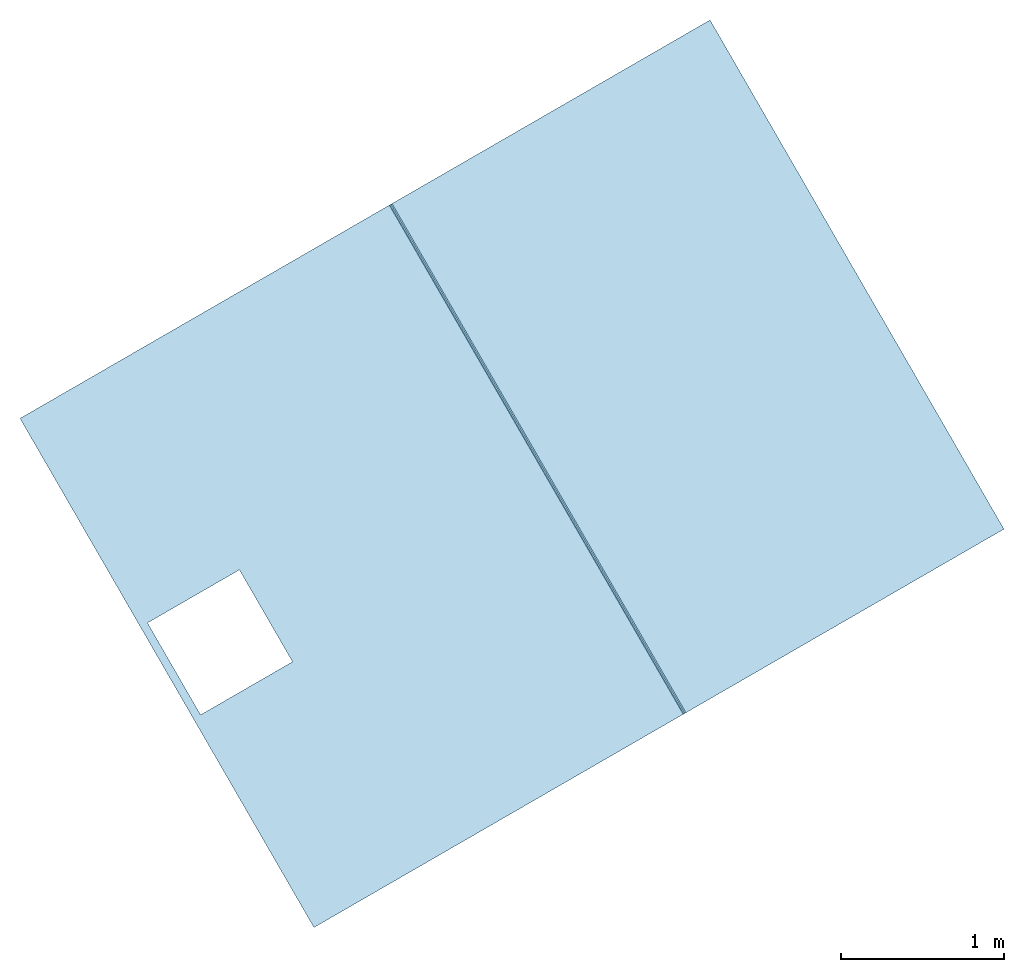
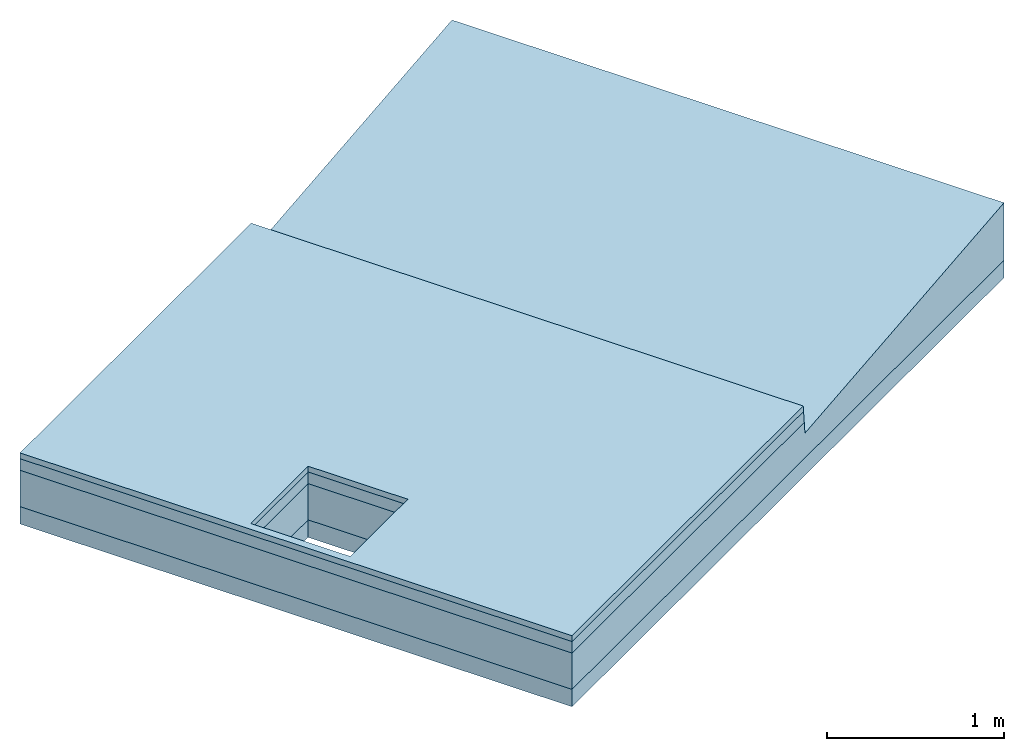
# One storey: 4 slabs.
"""IFC4 building model written with IfcOpenShell, lengths in millimetres."""

from ifc_helpers import new_model, si_unit, frame, origin_with_axes, place, context, subcontext, project, spatial, triangles, material, type_object, element, save


model = new_model("IFC4")

# Units and contexts
model_context = context("Model", 3, world=origin_with_axes())
body_context = subcontext(model_context, "Body", "Model", "MODEL_VIEW")
ifc_project = project(units=[si_unit("LENGTHUNIT", "METRE", prefix="MILLI"), si_unit("AREAUNIT", "SQUARE_METRE"), si_unit("VOLUMEUNIT", "CUBIC_METRE")], contexts=[model_context])

# Sites, buildings, storey
site_1_placement = place(None, origin_with_axes())
site_1 = spatial("IfcSite", under=ifc_project, at=site_1_placement, CompositionType="COMPLEX")
site_2_placement = place(site_1_placement, frame((17320.50807568878, 30000.000000000065, 0.0), z_axis=(0.0, 0.0, 1.0), x_axis=(-0.5000000000000003, 0.8660254037844387, 0.0)))
site_2 = spatial("IfcSite", under=site_1, at=site_2_placement, CompositionType="PARTIAL")
building_1_placement = place(site_2_placement, origin_with_axes())
building_1 = spatial("IfcBuilding", under=site_2, at=building_1_placement, Name="bridge road connection", CompositionType="COMPLEX")
building_2_placement = place(building_1_placement, frame((-8.374172466574236e-11, 4.3314685171935707e-10, 2.6349766812927553e-11), z_axis=(-1.5815362361441082e-15, -2.9936039337702353e-15, 1.0), x_axis=(-1.0, -2.786659791809143e-14, -1.5815362361441902e-15)))
building_2 = spatial("IfcBuilding", under=building_1, at=building_2_placement, Name="bridge - road segment", CompositionType="PARTIAL")
storey_placement = place(building_2_placement, frame((0.0, 0.0, 0.0), z_axis=(0.0, 0.0, 1.0), x_axis=(1.0, 4.73449309792135e-30, -3.944304526105059e-31)))
storey = spatial("IfcBuildingStorey", under=building_2, at=storey_placement, Name="road bridge road", CompositionType="ELEMENT", Elevation=2.6349766812927553e-11)

# Slabs
ifc_material_1 = material(Name="material_stone_generic")
slab_type_1 = type_object("IfcSlabType", Name="road base course - bridge road", PredefinedType="USERDEFINED")
slab_1_placement = place(storey_placement, frame((8.085407898761331e-11, -7560.249999996269, -1.8047785488317828e-13), z_axis=(0.0, 0.0, 1.0), x_axis=(1.0, 4.73449309792135e-30, -3.944304526105059e-31)))
element("IfcSlab", 1, at=slab_1_placement, inside=storey, type_object=slab_type_1, material=ifc_material_1, Name="road base course - bridge road", context=body_context, shape_type="Tessellation", body=[
    triangles([(1800.0000000000155, -2439.7499999956285, -489.99999999999505), (1800.0000000000184, 2439.7499999956285, -369.9999999999922), (1800.000000000027, -2439.74999999564, -369.99999999999216), (1800.0000000001107, 2439.749999995634, -489.99999999974705), (-1799.999999999981, -2439.7499999956285, -369.9999999999922), (-325.0000000009139, -2389.7500000114123, -369.99999999999216), (-1799.999999999978, 2439.74999999564, -369.9999999999922), (1800.000000000027, -2439.74999999564, -369.99999999999216), (-325.0000000009225, -1739.750000011416, -369.99999999999204), (324.99999999908283, -2389.7500000114123, -369.99999999999216), (324.9999999990829, -1739.750000011416, -369.99999999999204), (1800.0000000000184, 2439.7499999956285, -369.9999999999922), (1800.000000000027, -2439.74999999564, -369.99999999999216), (-1799.999999999981, -2439.7499999956285, -489.99999999999505), (1800.0000000000155, -2439.7499999956285, -489.99999999999505), (-1799.999999999981, -2439.7499999956285, -369.9999999999922), (-1799.999999999978, 2439.74999999564, -369.9999999999922), (1800.0000000001107, 2439.749999995634, -489.99999999974705), (-1800.0000000000819, 2439.749999995634, -489.9999999997472), (1800.0000000000184, 2439.7499999956285, -369.9999999999922), (-1799.999999999978, 2439.74999999564, -369.9999999999922), (-1799.999999999981, -2439.7499999956285, -489.99999999999505), (-1799.999999999981, -2439.7499999956285, -369.9999999999922), (-1800.0000000000819, 2439.749999995634, -489.9999999997472), (1800.0000000001107, 2439.749999995634, -489.99999999974705), (-1799.999999999981, -2439.7499999956285, -489.99999999999505), (-1800.0000000000819, 2439.749999995634, -489.9999999997472), (-325.0000000009138, -1739.750000011416, -489.9999999999943), (-325.00000000091677, -2389.7500000114183, -489.9999999999938), (324.99999999908, -1739.750000011416, -489.9999999999938), (324.99999999908283, -2389.7500000114183, -489.99999999999386), (1800.0000000000155, -2439.7499999956285, -489.99999999999505), (-325.00000000091677, -2389.7500000114183, -489.9999999999938), (324.99999999908283, -2389.7500000114123, -369.99999999999216), (324.99999999908283, -2389.7500000114183, -489.99999999999386), (-325.0000000009139, -2389.7500000114123, -369.99999999999216), (324.99999999908283, -2389.7500000114123, -369.99999999999216), (324.99999999908, -1739.750000011416, -489.9999999999938), (324.99999999908283, -2389.7500000114183, -489.99999999999386), (324.9999999990829, -1739.750000011416, -369.99999999999204), (324.99999999908, -1739.750000011416, -489.9999999999938), (-325.0000000009225, -1739.750000011416, -369.99999999999204), (-325.0000000009138, -1739.750000011416, -489.9999999999943), (324.9999999990829, -1739.750000011416, -369.99999999999204), (-325.0000000009138, -1739.750000011416, -489.9999999999943), (-325.0000000009139, -2389.7500000114123, -369.99999999999216), (-325.00000000091677, -2389.7500000114183, -489.9999999999938), (-325.0000000009225, -1739.750000011416, -369.99999999999204)], [[1, 2, 3], [2, 1, 4], [5, 6, 7], [6, 5, 8], [7, 6, 9], [6, 8, 10], [10, 8, 11], [11, 8, 12], [9, 12, 7], [12, 9, 11], [13, 14, 15], [14, 13, 16], [17, 18, 19], [18, 17, 20], [21, 22, 23], [22, 21, 24], [25, 26, 27], [26, 25, 28], [26, 28, 29], [28, 25, 30], [30, 25, 31], [31, 25, 32], [29, 32, 26], [32, 29, 31], [33, 34, 35], [34, 33, 36], [37, 38, 39], [38, 37, 40], [41, 42, 43], [42, 41, 44], [45, 46, 47], [46, 45, 48]]),
])
ifc_material_2 = material(Name="bitumen_generic")
slab_type_2 = type_object("IfcSlabType", Name="bridge road - road asphalt course", PredefinedType="USERDEFINED")
slab_2_placement = place(storey_placement, frame((0.0, 0.0, 0.0), z_axis=(0.0, 0.0, 1.0), x_axis=(1.0, 4.73449309792135e-30, -3.944304526105059e-31)))
element("IfcSlab", 2, at=slab_2_placement, inside=storey, type_object=slab_type_2, material=ifc_material_2, Name="bridge road - road asphalt course", ObjectType="core", context=body_context, shape_type="Tessellation", body=[
    triangles([(-1799.999999999984, -7384.611130885971, -39.999999999995964), (1800.0000000000289, -7376.611130886018, -119.99999999999653), (-1799.9999999999848, -7376.611130886019, -119.99999999999653), (1800.000000000029, -7384.61113088597, -39.999999999995964), (-1799.999999999984, -7384.611130885971, -39.999999999995964), (-1799.9999999999845, -10000.00000000001, -119.99999999999653), (-1799.9999999999848, -10000.00000000001, -39.99999999999524), (-1799.9999999999848, -7376.611130886019, -119.99999999999653), (-1799.9999999999848, -10000.00000000001, -39.99999999999524), (-325.00000000082576, -9950.000000007683, -39.99999999999583), (-1799.999999999984, -7384.611130885971, -39.999999999995964), (1800.0000000000284, -10000.00000000001, -39.99999999999524), (324.99999999917424, -9950.000000007682, -39.99999999999582), (324.9999999991793, -9300.000000007683, -39.99999999999597), (-325.0000000008209, -9300.000000007683, -39.99999999999599), (1800.000000000029, -7384.61113088597, -39.999999999995964), (1800.0000000000284, -10000.00000000001, -39.99999999999524), (-1799.9999999999845, -10000.00000000001, -119.99999999999653), (1800.0000000000289, -10000.00000000001, -119.99999999999653), (-1799.9999999999848, -10000.00000000001, -39.99999999999524), (1800.0000000000289, -7376.611130886018, -119.99999999999653), (-1799.9999999999845, -10000.00000000001, -119.99999999999653), (-1799.9999999999848, -7376.611130886019, -119.99999999999653), (-325.0000000008204, -9300.000000007683, -119.99999999999653), (-325.0000000008251, -9950.000000007683, -119.99999999999653), (324.9999999991751, -9300.000000007683, -119.99999999999653), (324.9999999991751, -9950.000000007682, -119.99999999999656), (1800.0000000000289, -10000.00000000001, -119.99999999999653), (1800.0000000000289, -7376.611130886018, -119.99999999999653), (1800.0000000000284, -10000.00000000001, -39.99999999999524), (1800.0000000000289, -10000.00000000001, -119.99999999999653), (1800.000000000029, -7384.61113088597, -39.999999999995964), (324.9999999991793, -9300.000000007683, -39.99999999999597), (-325.0000000008204, -9300.000000007683, -119.99999999999653), (324.9999999991751, -9300.000000007683, -119.99999999999653), (-325.0000000008209, -9300.000000007683, -39.99999999999599), (-325.0000000008204, -9300.000000007683, -119.99999999999653), (-325.00000000082576, -9950.000000007683, -39.99999999999583), (-325.0000000008251, -9950.000000007683, -119.99999999999653), (-325.0000000008209, -9300.000000007683, -39.99999999999599), (-325.0000000008251, -9950.000000007683, -119.99999999999653), (324.99999999917424, -9950.000000007682, -39.99999999999582), (324.9999999991751, -9950.000000007682, -119.99999999999656), (-325.00000000082576, -9950.000000007683, -39.99999999999583), (324.9999999991793, -9300.000000007683, -39.99999999999597), (324.9999999991751, -9950.000000007682, -119.99999999999656), (324.99999999917424, -9950.000000007682, -39.99999999999582), (324.9999999991751, -9300.000000007683, -119.99999999999653)], [[1, 2, 3], [2, 1, 4], [5, 6, 7], [6, 5, 8], [9, 10, 11], [10, 9, 12], [10, 12, 13], [13, 12, 14], [11, 15, 16], [15, 11, 10], [16, 15, 14], [16, 14, 12], [17, 18, 19], [18, 17, 20], [21, 22, 23], [22, 21, 24], [22, 24, 25], [24, 21, 26], [26, 21, 27], [25, 28, 22], [28, 25, 27], [28, 27, 21], [29, 30, 31], [30, 29, 32], [33, 34, 35], [34, 33, 36], [37, 38, 39], [38, 37, 40], [41, 42, 43], [42, 41, 44], [45, 46, 47], [46, 45, 48]]),
])
ifc_material_3 = material(Name="material_gravel_generic")
slab_type_3 = type_object("IfcSlabType", Name="road bridge road", PredefinedType="USERDEFINED")
slab_3_placement = place(storey_placement, frame((0.0, 0.0, 0.0), z_axis=(0.0, 0.0, 1.0), x_axis=(1.0, 4.73449309792135e-30, -3.944304526105059e-31)))
element("IfcSlab", 3, at=slab_3_placement, inside=storey, type_object=slab_type_3, material=ifc_material_3, Name="road bridge road", context=body_context, shape_type="Tessellation", body=[
    triangles([(1800.0000000000123, -5120.500000000176, -369.9999999999924), (1800.0000000000177, -10000.000000000033, -119.99999999999577), (1800.0000000000118, -10000.000000000033, -369.9999999999924), (1800.0000000000064, -7368.710387081809, -199.0074380419954), (1800.0000000000123, -7376.611130886025, -119.99999999999574), (1800.0000000000123, -5120.500000000211, 25.81360066616533), (1800.000000000018, -5120.5000000001655, -119.9999999999958), (-1799.9999999999811, -5120.500000000159, -119.99999999999577), (1800.0000000000123, -5120.500000000176, -369.9999999999924), (-1799.999999999984, -5120.500000000159, -369.9999999999924), (1800.000000000018, -5120.5000000001655, -119.9999999999958), (1800.0000000000123, -5120.500000000211, 25.81360066616533), (-1799.9999999999898, -5120.500000000206, 25.813600666093855), (-1799.9999999999957, -7376.611130886019, -119.9999999998644), (-1799.9999999999902, -10000.000000000033, -369.9999999999924), (-1799.9999999999902, -10000.000000000033, -119.9999999999958), (-1799.9999999999957, -7368.710387081815, -199.00743804186402), (-1799.999999999984, -5120.500000000159, -369.9999999999924), (-1799.9999999999898, -5120.500000000206, 25.813600666093855), (-1799.9999999999811, -5120.500000000159, -119.99999999999577), (1800.0000000000177, -10000.000000000033, -119.99999999999577), (-325.00000000083054, -9950.000000007685, -119.99999999997891), (-1799.9999999999902, -10000.000000000033, -119.9999999999958), (324.99999999917486, -9950.00000000768, -119.9999999999908), (324.9999999991749, -9300.00000000769, -119.9999999999771), (1800.0000000000123, -7376.611130886025, -119.99999999999574), (-1799.9999999999957, -7376.611130886019, -119.9999999998644), (-325.00000000082764, -9300.00000000769, -119.99999999996528), (-1799.9999999999957, -7368.710387081815, -199.00743804186402), (1800.0000000000123, -7376.611130886025, -119.99999999999574), (1800.0000000000064, -7368.710387081809, -199.0074380419954), (-1799.9999999999957, -7376.611130886019, -119.9999999998644), (1800.0000000000064, -7368.710387081809, -199.0074380419954), (-1799.9999999999898, -5120.500000000206, 25.813600666093855), (-1799.9999999999957, -7368.710387081815, -199.00743804186402), (1800.0000000000123, -5120.500000000211, 25.81360066616533), (1800.0000000000177, -10000.000000000033, -119.99999999999577), (-1799.9999999999902, -10000.000000000033, -369.9999999999924), (1800.0000000000118, -10000.000000000033, -369.9999999999924), (-1799.9999999999902, -10000.000000000033, -119.9999999999958), (1800.0000000000123, -5120.500000000176, -369.9999999999924), (-325.00000000082764, -9300.000000007683, -369.9999999999924), (-1799.999999999984, -5120.500000000159, -369.9999999999924), (324.9999999991691, -9300.000000007683, -369.9999999999924), (324.99999999917776, -9950.00000000768, -369.9999999999924), (-1799.9999999999902, -10000.000000000033, -369.9999999999924), (-325.0000000008219, -9950.000000007685, -369.9999999999924), (1800.0000000000118, -10000.000000000033, -369.9999999999924), (324.9999999991749, -9300.00000000769, -119.9999999999771), (-325.00000000082764, -9300.000000007683, -369.9999999999924), (324.9999999991691, -9300.000000007683, -369.9999999999924), (-325.00000000082764, -9300.00000000769, -119.99999999996528), (-325.00000000082764, -9300.000000007683, -369.9999999999924), (-325.00000000083054, -9950.000000007685, -119.99999999997891), (-325.0000000008219, -9950.000000007685, -369.9999999999924), (-325.00000000082764, -9300.00000000769, -119.99999999996528), (-325.00000000083054, -9950.000000007685, -119.99999999997891), (324.99999999917776, -9950.00000000768, -369.9999999999924), (-325.0000000008219, -9950.000000007685, -369.9999999999924), (324.99999999917486, -9950.00000000768, -119.9999999999908), (324.9999999991749, -9300.00000000769, -119.9999999999771), (324.99999999917776, -9950.00000000768, -369.9999999999924), (324.99999999917486, -9950.00000000768, -119.9999999999908), (324.9999999991691, -9300.000000007683, -369.9999999999924)], [[1, 2, 3], [2, 1, 4], [2, 4, 5], [4, 1, 6], [6, 1, 7], [8, 9, 10], [9, 8, 11], [11, 8, 12], [12, 8, 13], [14, 15, 16], [15, 14, 17], [15, 17, 18], [18, 17, 19], [18, 19, 20], [21, 22, 23], [22, 21, 24], [24, 21, 25], [25, 21, 26], [23, 26, 27], [26, 23, 28], [28, 23, 22], [26, 28, 25], [29, 30, 31], [30, 29, 32], [33, 34, 35], [34, 33, 36], [37, 38, 39], [38, 37, 40], [41, 42, 43], [42, 41, 44], [44, 41, 45], [46, 47, 48], [47, 46, 43], [47, 43, 42], [48, 47, 45], [48, 45, 41], [49, 50, 51], [50, 49, 52], [53, 54, 55], [54, 53, 56], [57, 58, 59], [58, 57, 60], [61, 62, 63], [62, 61, 64]]),
])
ifc_material_4 = material(Name="bitumen_asphalt_generic")
slab_type_4 = type_object("IfcSlabType", Name="road asphalt surface course - bridge road", PredefinedType="USERDEFINED")
slab_4_placement = place(storey_placement, frame((0.0, 0.0, 0.0), z_axis=(0.0, 0.0, 1.0), x_axis=(1.0, 4.73449309792135e-30, -3.944304526105059e-31)))
element("IfcSlab", 4, at=slab_4_placement, inside=storey, type_object=slab_type_4, material=ifc_material_4, Name="road asphalt surface course - bridge road", ObjectType="pavement", context=body_context, shape_type="Tessellation", body=[
    triangles([(-1799.9999999999725, -7388.611130885947, 4.334111182094733e-12), (1800.0000000000239, -7384.611130885971, -39.99999999999596), (-1799.999999999987, -7384.611130885971, -39.99999999999597), (1800.0000000000239, -7388.611130885953, 4.3313093374670805e-12), (1800.0000000000239, -7384.611130885971, -39.99999999999596), (1800.000000000032, -10000.00000000001, 4.33079243590631e-12), (1800.000000000032, -10000.00000000001, -39.99999999999596), (1800.0000000000239, -7388.611130885953, 4.3313093374670805e-12), (-1799.999999999987, -7384.611130885971, -39.99999999999597), (-325.00000000082474, -9300.000000007678, -39.999999999995964), (-325.00000000083344, -9950.00000000768, -39.999999999995964), (1800.0000000000239, -7384.611130885971, -39.99999999999596), (324.9999999991633, -9300.000000007683, -39.99999999999595), (324.99999999917486, -9950.000000007685, -39.99999999999595), (-1799.9999999999932, -10000.00000000001, -39.99999999999594), (1800.000000000032, -10000.00000000001, -39.99999999999596), (1800.000000000032, -10000.00000000001, 4.33079243590631e-12), (-1799.9999999999932, -10000.00000000001, -39.99999999999594), (1800.000000000032, -10000.00000000001, -39.99999999999596), (-1799.9999999999932, -10000.00000000001, 4.333594280534003e-12), (-1799.9999999999932, -10000.00000000001, 4.333594280534003e-12), (-325.000000000819, -9950.00000000768, 4.3344699208686615e-12), (-1799.9999999999725, -7388.611130885947, 4.334111182094733e-12), (1800.000000000032, -10000.00000000001, 4.33079243590631e-12), (-325.00000000082474, -9300.000000007678, 4.334535604861225e-12), (324.99999999917486, -9950.000000007685, 4.3472805406451975e-12), (1800.0000000000239, -7388.611130885953, 4.3313093374670805e-12), (324.9999999991633, -9300.000000007683, 4.34734622463776e-12), (-1799.9999999999725, -7388.611130885947, 4.334111182094733e-12), (-1799.9999999999932, -10000.00000000001, -39.99999999999594), (-1799.9999999999932, -10000.00000000001, 4.333594280534003e-12), (-1799.999999999987, -7384.611130885971, -39.99999999999597), (-325.000000000819, -9950.00000000768, 4.3344699208686615e-12), (324.99999999917486, -9950.000000007685, -39.99999999999595), (-325.00000000083344, -9950.00000000768, -39.999999999995964), (324.99999999917486, -9950.000000007685, 4.3472805406451975e-12), (-325.00000000082474, -9300.000000007678, -39.999999999995964), (-325.000000000819, -9950.00000000768, 4.3344699208686615e-12), (-325.00000000083344, -9950.00000000768, -39.999999999995964), (-325.00000000082474, -9300.000000007678, 4.334535604861225e-12), (324.9999999991633, -9300.000000007683, 4.34734622463776e-12), (324.99999999917486, -9950.000000007685, -39.99999999999595), (324.99999999917486, -9950.000000007685, 4.3472805406451975e-12), (324.9999999991633, -9300.000000007683, -39.99999999999595), (324.9999999991633, -9300.000000007683, -39.99999999999595), (-325.00000000082474, -9300.000000007678, 4.334535604861225e-12), (-325.00000000082474, -9300.000000007678, -39.999999999995964), (324.9999999991633, -9300.000000007683, 4.34734622463776e-12)], [[1, 2, 3], [2, 1, 4], [5, 6, 7], [6, 5, 8], [9, 10, 11], [10, 9, 12], [10, 12, 13], [13, 12, 14], [15, 11, 16], [11, 15, 9], [16, 11, 14], [16, 14, 12], [17, 18, 19], [18, 17, 20], [21, 22, 23], [22, 21, 24], [23, 22, 25], [22, 24, 26], [26, 24, 27], [25, 27, 23], [27, 25, 28], [27, 28, 26], [29, 30, 31], [30, 29, 32], [33, 34, 35], [34, 33, 36], [37, 38, 39], [38, 37, 40], [41, 42, 43], [42, 41, 44], [45, 46, 47], [46, 45, 48]]),
])

save(model, "model.ifc")
